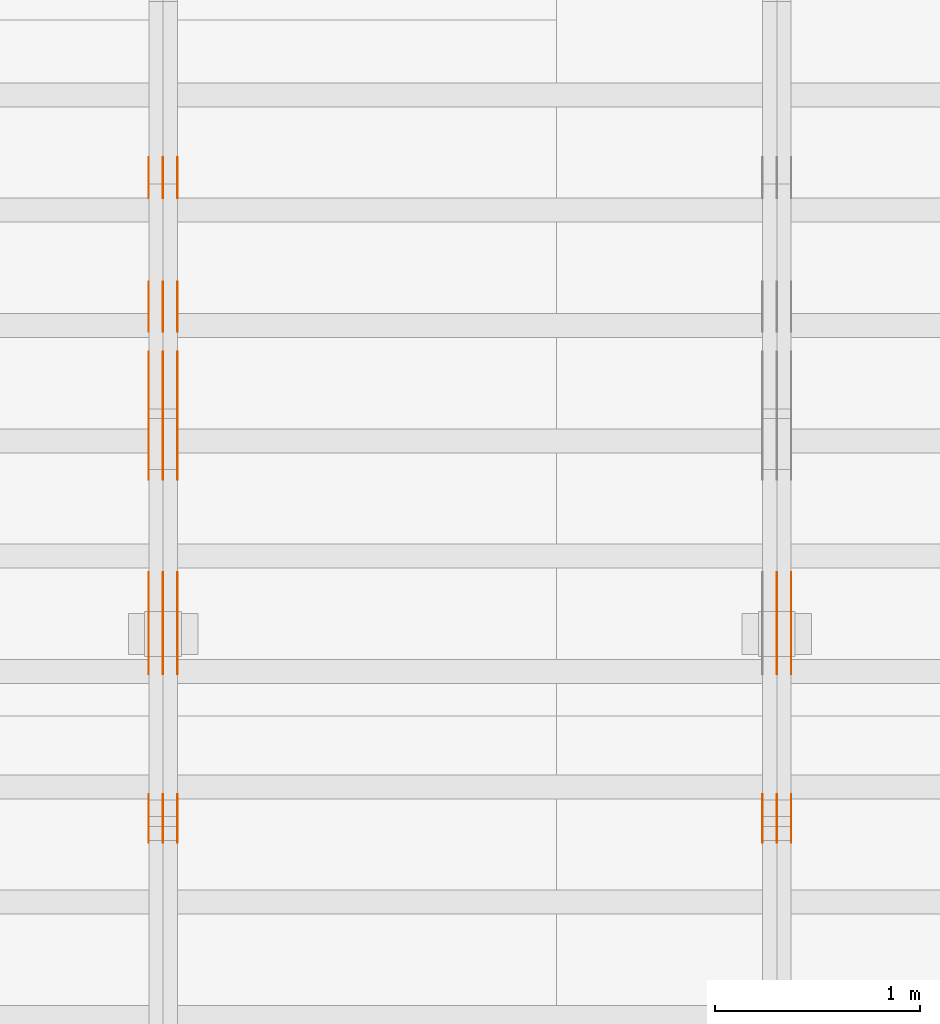
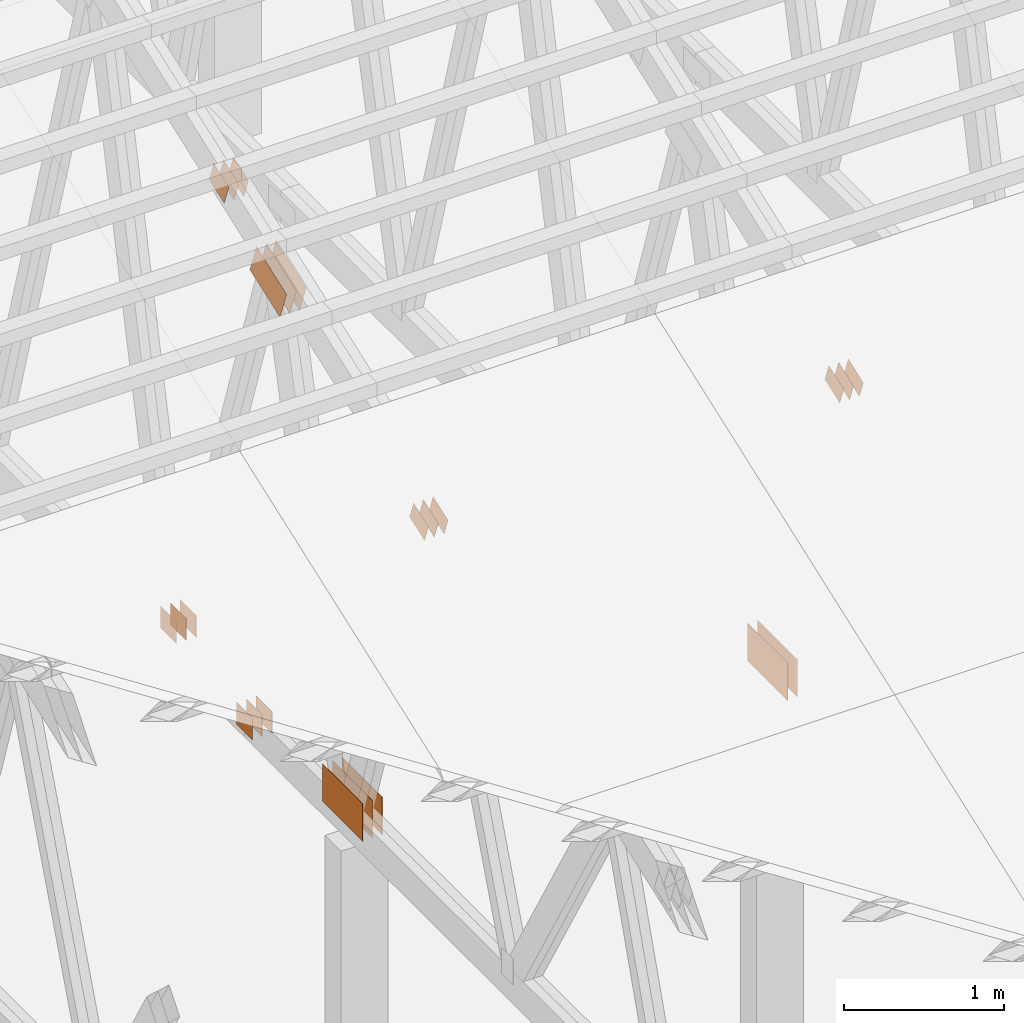
# One storey, part 145 of 189: 31 proxies.
"""IFC2X3 building model written with IfcOpenShell, lengths in millimetres."""

from ifc_helpers import new_model, entity, si_unit, converted_unit, derived_unit, direction, frame, frame_2d, origin, origin_2d_with_axis, place, context, subcontext, project, spatial, polyline, rectangle, outline, extrude, source, transform, mapped, material, type_object, type_shapes, element, save


model = new_model("IFC2X3")

# Units and contexts
model_context = context("Model", 3, precision=0.01, world=origin(), true_north=direction((6.12303176911189e-17, 1.0)))
body_context = subcontext(model_context, "Body", "Model", "MODEL_VIEW")
ifc_project = project(units=[si_unit("LENGTHUNIT", "METRE", prefix="MILLI"), si_unit("AREAUNIT", "SQUARE_METRE"), si_unit("VOLUMEUNIT", "CUBIC_METRE"), converted_unit("PLANEANGLEUNIT", "DEGREE", entity("IfcRatioMeasure", 0.0174532925199433), si_unit("PLANEANGLEUNIT", "RADIAN"), dimensions=[0, 0, 0, 0, 0, 0, 0]), si_unit("MASSUNIT", "GRAM", prefix="KILO"), derived_unit("MASSDENSITYUNIT", [(si_unit("MASSUNIT", "GRAM", prefix="KILO"), 1), (si_unit("LENGTHUNIT", "METRE"), -3)]), si_unit("TIMEUNIT", "SECOND"), si_unit("FREQUENCYUNIT", "HERTZ"), si_unit("THERMODYNAMICTEMPERATUREUNIT", "DEGREE_CELSIUS"), derived_unit("THERMALTRANSMITTANCEUNIT", [(si_unit("MASSUNIT", "GRAM", prefix="KILO"), 1), (si_unit("THERMODYNAMICTEMPERATUREUNIT", "KELVIN"), -1), (si_unit("TIMEUNIT", "SECOND"), -3)]), derived_unit("VOLUMETRICFLOWRATEUNIT", [(si_unit("LENGTHUNIT", "METRE"), 3), (si_unit("TIMEUNIT", "SECOND"), -1)]), si_unit("ELECTRICCURRENTUNIT", "AMPERE"), si_unit("ELECTRICVOLTAGEUNIT", "VOLT"), si_unit("POWERUNIT", "WATT"), si_unit("FORCEUNIT", "NEWTON"), si_unit("ILLUMINANCEUNIT", "LUX"), si_unit("LUMINOUSFLUXUNIT", "LUMEN"), si_unit("LUMINOUSINTENSITYUNIT", "CANDELA"), derived_unit("USERDEFINED", [(si_unit("MASSUNIT", "GRAM", prefix="KILO"), -1), (si_unit("LENGTHUNIT", "METRE"), -2), (si_unit("TIMEUNIT", "SECOND"), 3), (si_unit("LUMINOUSFLUXUNIT", "LUMEN"), 1)]), derived_unit("LINEARVELOCITYUNIT", [(si_unit("LENGTHUNIT", "METRE"), 1), (si_unit("TIMEUNIT", "SECOND"), -1)]), si_unit("PRESSUREUNIT", "PASCAL"), derived_unit("USERDEFINED", [(si_unit("LENGTHUNIT", "METRE"), -2), (si_unit("MASSUNIT", "GRAM", prefix="KILO"), 1), (si_unit("TIMEUNIT", "SECOND"), -2)])], contexts=[model_context])

# Site, building, storey
site_placement = place(None, origin())
site = spatial("IfcSite", under=ifc_project, at=site_placement, CompositionType="ELEMENT")
building_placement = place(site_placement, origin())
building = spatial("IfcBuilding", under=site, at=building_placement, CompositionType="ELEMENT")
storey_placement = place(building_placement, origin())
storey = spatial("IfcBuildingStorey", under=building, at=storey_placement, Name="Default", CompositionType="ELEMENT", Elevation=0.0)

# Proxies
ifc_material_1 = material(Name="IfcSurfaceStyle #202358")
building_element_proxy_type_1 = type_object("IfcBuildingElementProxyType", PredefinedType="NOTDEFINED", material=ifc_material_1)
shared_shape_1 = source(origin(), body_context, "Body", "SweptSolid", [
    extrude(rectangle(XDim=500.0, YDim=288.0, at=frame_2d((0.0, 1.4210854715202e-14), x_axis=(1.0, 0.0))), frame((250.000973740011, 144.0, 0.0), z_axis=(0.0, 0.0, 1.0), x_axis=(-1.0, 0.0, 0.0)), (0.0, 0.0, 1.0), 1.29999999999998),
])
type_shapes(building_element_proxy_type_1, [shared_shape_1])
proxy_1_placement = place(building_placement, frame((36301.3, 8551.90918250999, 389.0), z_axis=(-1.0, 0.0, 0.0), x_axis=(0.0, 1.0, 0.0)))
element("IfcBuildingElementProxy", 1, at=proxy_1_placement, inside=storey, type_object=building_element_proxy_type_1, material=ifc_material_1, context=body_context, shape_type="MappedRepresentation", body=[
    mapped(shared_shape_1, transform((0.0, 0.0, 0.0), scale=1.0)),
])
ifc_material_2 = material(Name="IfcSurfaceStyle #202301")
building_element_proxy_type_2 = type_object("IfcBuildingElementProxyType", PredefinedType="NOTDEFINED", material=ifc_material_2)
shared_shape_2 = source(origin(), body_context, "Body", "SweptSolid", [
    extrude(rectangle(XDim=500.0, YDim=288.0, at=frame_2d((0.0, 1.4210854715202e-14), x_axis=(1.0, 0.0))), frame((250.000973740011, 144.0, 0.0), z_axis=(0.0, 0.0, 1.0), x_axis=(-1.0, 0.0, 0.0)), (0.0, 0.0, 1.0), 1.29999999999997),
])
type_shapes(building_element_proxy_type_2, [shared_shape_2])
proxy_2_placement = place(building_placement, frame((36230.0, 8551.90918250999, 389.0), z_axis=(-1.0, 0.0, 0.0), x_axis=(0.0, 1.0, 0.0)))
element("IfcBuildingElementProxy", 2, at=proxy_2_placement, inside=storey, type_object=building_element_proxy_type_2, material=ifc_material_2, context=body_context, shape_type="MappedRepresentation", body=[
    mapped(shared_shape_2, transform((0.0, 0.0, 0.0), scale=1.0)),
])
ifc_material_3 = material(Name="IfcSurfaceStyle #202244")
building_element_proxy_type_3 = type_object("IfcBuildingElementProxyType", PredefinedType="NOTDEFINED", material=ifc_material_3)
shared_shape_3 = source(origin(), body_context, "Body", "SweptSolid", [
    extrude(rectangle(XDim=500.0, YDim=288.0, at=frame_2d((0.0, 1.4210854715202e-14), x_axis=(1.0, 0.0))), frame((250.000973740011, 144.0, 0.0), z_axis=(0.0, 0.0, 1.0), x_axis=(-1.0, 0.0, 0.0)), (0.0, 0.0, 1.0), 1.29999999999997),
])
type_shapes(building_element_proxy_type_3, [shared_shape_3])
proxy_3_placement = place(building_placement, frame((36231.3, 8551.90918250999, 389.0), z_axis=(-1.0, 0.0, 0.0), x_axis=(0.0, 1.0, 0.0)))
element("IfcBuildingElementProxy", 3, at=proxy_3_placement, inside=storey, type_object=building_element_proxy_type_3, material=ifc_material_3, context=body_context, shape_type="MappedRepresentation", body=[
    mapped(shared_shape_3, transform((0.0, 0.0, 0.0), scale=1.0)),
])
ifc_material_4 = material(Name="IfcSurfaceStyle #202130")
building_element_proxy_type_4 = type_object("IfcBuildingElementProxyType", PredefinedType="NOTDEFINED", material=ifc_material_4)
shared_shape_4 = source(origin(), body_context, "Body", "SweptSolid", [
    extrude(outline(polyline([(-100.00048713087, -72.0000025659129), (100.000394045495, -72.0000025659129), (99.9995694622958, 72.0000025659129), (-99.9994763769209, 72.0000025659128), (-100.00048713087, -72.0000025659129)])), frame((100.000394045495, 72.0000025659128, 0.0), z_axis=(0.0, 0.0, 1.0), x_axis=(-1.0, 0.0, 0.0)), (0.0, 0.0, 1.0), 1.3),
])
type_shapes(building_element_proxy_type_4, [shared_shape_4])
proxy_4_placement = place(building_placement, frame((36301.3, 7965.16887114408, 2936.19963864386), z_axis=(-1.0, 0.0, 0.0), x_axis=(0.0, -0.939692620785908, -0.342020143325669)))
element("IfcBuildingElementProxy", 4, at=proxy_4_placement, inside=storey, type_object=building_element_proxy_type_4, material=ifc_material_4, context=body_context, shape_type="MappedRepresentation", body=[
    mapped(shared_shape_4, transform((0.0, 0.0, 0.0), scale=1.0)),
])
ifc_material_5 = material(Name="IfcSurfaceStyle #202073")
building_element_proxy_type_5 = type_object("IfcBuildingElementProxyType", PredefinedType="NOTDEFINED", material=ifc_material_5)
shared_shape_5 = source(origin(), body_context, "Body", "SweptSolid", [
    extrude(outline(polyline([(-100.00048713087, -72.0000025659129), (100.000394045495, -72.0000025659129), (99.9995694622958, 72.0000025659129), (-99.9994763769209, 72.0000025659128), (-100.00048713087, -72.0000025659129)])), frame((100.000394045495, 72.0000025659128, 0.0), z_axis=(0.0, 0.0, 1.0), x_axis=(-1.0, 0.0, 0.0)), (0.0, 0.0, 1.0), 1.29999999999998),
])
type_shapes(building_element_proxy_type_5, [shared_shape_5])
proxy_5_placement = place(building_placement, frame((36230.0, 7965.16887114408, 2936.19963864386), z_axis=(-1.0, 0.0, 0.0), x_axis=(0.0, -0.939692620785908, -0.342020143325669)))
element("IfcBuildingElementProxy", 5, at=proxy_5_placement, inside=storey, type_object=building_element_proxy_type_5, material=ifc_material_5, context=body_context, shape_type="MappedRepresentation", body=[
    mapped(shared_shape_5, transform((0.0, 0.0, 0.0), scale=1.0)),
])
ifc_material_6 = material(Name="IfcSurfaceStyle #202016")
building_element_proxy_type_6 = type_object("IfcBuildingElementProxyType", PredefinedType="NOTDEFINED", material=ifc_material_6)
shared_shape_6 = source(origin(), body_context, "Body", "SweptSolid", [
    extrude(outline(polyline([(-100.00048713087, -72.0000025659129), (100.000394045495, -72.0000025659129), (99.9995694622958, 72.0000025659129), (-99.9994763769209, 72.0000025659128), (-100.00048713087, -72.0000025659129)])), frame((100.000394045495, 72.0000025659128, 0.0), z_axis=(0.0, 0.0, 1.0), x_axis=(-1.0, 0.0, 0.0)), (0.0, 0.0, 1.0), 1.29999999999998),
])
type_shapes(building_element_proxy_type_6, [shared_shape_6])
proxy_6_placement = place(building_placement, frame((36231.3, 7965.16887114408, 2936.19963864386), z_axis=(-1.0, 0.0, 0.0), x_axis=(0.0, -0.939692620785908, -0.342020143325669)))
element("IfcBuildingElementProxy", 6, at=proxy_6_placement, inside=storey, type_object=building_element_proxy_type_6, material=ifc_material_6, context=body_context, shape_type="MappedRepresentation", body=[
    mapped(shared_shape_6, transform((0.0, 0.0, 0.0), scale=1.0)),
])
ifc_material_7 = material(Name="IfcSurfaceStyle #201959")
building_element_proxy_type_7 = type_object("IfcBuildingElementProxyType", PredefinedType="NOTDEFINED", material=ifc_material_7)
shared_shape_7 = source(origin(), body_context, "Body", "SweptSolid", [
    extrude(outline(polyline([(-100.00048713087, -72.0000025659129), (100.000394045495, -72.0000025659129), (99.9995694622958, 72.0000025659129), (-99.9994763769209, 72.0000025659128), (-100.00048713087, -72.0000025659129)])), frame((100.000394045495, 72.0000025659128, 0.0), z_axis=(0.0, 0.0, 1.0), x_axis=(-1.0, 0.0, 0.0)), (0.0, 0.0, 1.0), 1.29999999999999),
])
type_shapes(building_element_proxy_type_7, [shared_shape_7])
proxy_7_placement = place(building_placement, frame((36160.0, 7965.16887114408, 2936.19963864386), z_axis=(-1.0, 0.0, 0.0), x_axis=(0.0, -0.939692620785908, -0.342020143325669)))
element("IfcBuildingElementProxy", 7, at=proxy_7_placement, inside=storey, type_object=building_element_proxy_type_7, material=ifc_material_7, context=body_context, shape_type="MappedRepresentation", body=[
    mapped(shared_shape_7, transform((0.0, 0.0, 0.0), scale=1.0)),
])
ifc_material_8 = material(Name="IfcSurfaceStyle #187480")
building_element_proxy_type_8 = type_object("IfcBuildingElementProxyType", PredefinedType="NOTDEFINED", material=ifc_material_8)
shared_shape_8 = source(origin(), body_context, "Body", "SweptSolid", [
    extrude(rectangle(XDim=200.0, YDim=168.0, at=origin_2d_with_axis()), frame((100.000765376775, 84.0, 0.0), z_axis=(0.0, 0.0, 1.0), x_axis=(-1.0, 0.0, 0.0)), (0.0, 0.0, 1.0), 1.3),
])
type_shapes(building_element_proxy_type_8, [shared_shape_8])
proxy_8_placement = place(building_placement, frame((33301.3, 10880.1574377482, 365.0), z_axis=(-1.0, 0.0, 0.0), x_axis=(0.0, 1.0, 0.0)))
element("IfcBuildingElementProxy", 8, at=proxy_8_placement, inside=storey, type_object=building_element_proxy_type_8, material=ifc_material_8, context=body_context, shape_type="MappedRepresentation", body=[
    mapped(shared_shape_8, transform((0.0, 0.0, 0.0), scale=1.0)),
])
ifc_material_9 = material(Name="IfcSurfaceStyle #187423")
building_element_proxy_type_9 = type_object("IfcBuildingElementProxyType", PredefinedType="NOTDEFINED", material=ifc_material_9)
shared_shape_9 = source(origin(), body_context, "Body", "SweptSolid", [
    extrude(rectangle(XDim=200.0, YDim=168.0, at=origin_2d_with_axis()), frame((100.000765376775, 84.0, 0.0), z_axis=(0.0, 0.0, 1.0), x_axis=(-1.0, 0.0, 0.0)), (0.0, 0.0, 1.0), 1.29999999999998),
])
type_shapes(building_element_proxy_type_9, [shared_shape_9])
proxy_9_placement = place(building_placement, frame((33230.0, 10880.1574377482, 365.0), z_axis=(-1.0, 0.0, 0.0), x_axis=(0.0, 1.0, 0.0)))
element("IfcBuildingElementProxy", 9, at=proxy_9_placement, inside=storey, type_object=building_element_proxy_type_9, material=ifc_material_9, context=body_context, shape_type="MappedRepresentation", body=[
    mapped(shared_shape_9, transform((0.0, 0.0, 0.0), scale=1.0)),
])
ifc_material_10 = material(Name="IfcSurfaceStyle #187366")
building_element_proxy_type_10 = type_object("IfcBuildingElementProxyType", PredefinedType="NOTDEFINED", material=ifc_material_10)
shared_shape_10 = source(origin(), body_context, "Body", "SweptSolid", [
    extrude(rectangle(XDim=200.0, YDim=168.0, at=origin_2d_with_axis()), frame((100.000765376775, 84.0, 0.0), z_axis=(0.0, 0.0, 1.0), x_axis=(-1.0, 0.0, 0.0)), (0.0, 0.0, 1.0), 1.29999999999998),
])
type_shapes(building_element_proxy_type_10, [shared_shape_10])
proxy_10_placement = place(building_placement, frame((33231.3, 10880.1574377482, 365.0), z_axis=(-1.0, 0.0, 0.0), x_axis=(0.0, 1.0, 0.0)))
element("IfcBuildingElementProxy", 10, at=proxy_10_placement, inside=storey, type_object=building_element_proxy_type_10, material=ifc_material_10, context=body_context, shape_type="MappedRepresentation", body=[
    mapped(shared_shape_10, transform((0.0, 0.0, 0.0), scale=1.0)),
])
ifc_material_11 = material(Name="IfcSurfaceStyle #187309")
building_element_proxy_type_11 = type_object("IfcBuildingElementProxyType", PredefinedType="NOTDEFINED", material=ifc_material_11)
shared_shape_11 = source(origin(), body_context, "Body", "SweptSolid", [
    extrude(rectangle(XDim=200.0, YDim=168.0, at=origin_2d_with_axis()), frame((100.000765376775, 84.0, 0.0), z_axis=(0.0, 0.0, 1.0), x_axis=(-1.0, 0.0, 0.0)), (0.0, 0.0, 1.0), 1.29999999999999),
])
type_shapes(building_element_proxy_type_11, [shared_shape_11])
proxy_11_placement = place(building_placement, frame((33160.0, 10880.1574377482, 365.0), z_axis=(-1.0, 0.0, 0.0), x_axis=(0.0, 1.0, 0.0)))
element("IfcBuildingElementProxy", 11, at=proxy_11_placement, inside=storey, type_object=building_element_proxy_type_11, material=ifc_material_11, context=body_context, shape_type="MappedRepresentation", body=[
    mapped(shared_shape_11, transform((0.0, 0.0, 0.0), scale=1.0)),
])
ifc_material_12 = material(Name="IfcSurfaceStyle #187252")
building_element_proxy_type_12 = type_object("IfcBuildingElementProxyType", PredefinedType="NOTDEFINED", material=ifc_material_12)
shared_shape_12 = source(origin(), body_context, "Body", "SweptSolid", [
    extrude(outline(polyline([(-199.999582244654, -119.99984375717), (200.000344770932, -119.99984375717), (199.999582244655, 119.99984375717), (-200.000344770934, 119.99984375717), (-199.999582244654, -119.99984375717)])), frame((200.000344770932, 120.0000091947, 0.0), z_axis=(0.0, 0.0, 1.0), x_axis=(-1.0, 0.0, 0.0)), (0.0, 0.0, 1.0), 1.29999999999999),
])
type_shapes(building_element_proxy_type_12, [shared_shape_12])
proxy_12_placement = place(building_placement, frame((33301.3, 9961.90704972973, 3612.2451494258), z_axis=(-1.0, 0.0, 0.0), x_axis=(0.0, -0.939692620785908, -0.342020143325669)))
element("IfcBuildingElementProxy", 12, at=proxy_12_placement, inside=storey, type_object=building_element_proxy_type_12, material=ifc_material_12, context=body_context, shape_type="MappedRepresentation", body=[
    mapped(shared_shape_12, transform((0.0, 0.0, 0.0), scale=1.0)),
])
ifc_material_13 = material(Name="IfcSurfaceStyle #187195")
building_element_proxy_type_13 = type_object("IfcBuildingElementProxyType", PredefinedType="NOTDEFINED", material=ifc_material_13)
shared_shape_13 = source(origin(), body_context, "Body", "SweptSolid", [
    extrude(outline(polyline([(-199.999582244654, -119.99984375717), (200.000344770932, -119.99984375717), (199.999582244655, 119.99984375717), (-200.000344770934, 119.99984375717), (-199.999582244654, -119.99984375717)])), frame((200.000344770932, 120.0000091947, 0.0), z_axis=(0.0, 0.0, 1.0), x_axis=(-1.0, 0.0, 0.0)), (0.0, 0.0, 1.0), 1.29999999999997),
])
type_shapes(building_element_proxy_type_13, [shared_shape_13])
proxy_13_placement = place(building_placement, frame((33230.0, 9961.90704972973, 3612.2451494258), z_axis=(-1.0, 0.0, 0.0), x_axis=(0.0, -0.939692620785908, -0.342020143325669)))
element("IfcBuildingElementProxy", 13, at=proxy_13_placement, inside=storey, type_object=building_element_proxy_type_13, material=ifc_material_13, context=body_context, shape_type="MappedRepresentation", body=[
    mapped(shared_shape_13, transform((0.0, 0.0, 0.0), scale=1.0)),
])
ifc_material_14 = material(Name="IfcSurfaceStyle #187138")
building_element_proxy_type_14 = type_object("IfcBuildingElementProxyType", PredefinedType="NOTDEFINED", material=ifc_material_14)
shared_shape_14 = source(origin(), body_context, "Body", "SweptSolid", [
    extrude(outline(polyline([(-199.999582244654, -119.99984375717), (200.000344770932, -119.99984375717), (199.999582244655, 119.99984375717), (-200.000344770934, 119.99984375717), (-199.999582244654, -119.99984375717)])), frame((200.000344770932, 120.0000091947, 0.0), z_axis=(0.0, 0.0, 1.0), x_axis=(-1.0, 0.0, 0.0)), (0.0, 0.0, 1.0), 1.29999999999997),
])
type_shapes(building_element_proxy_type_14, [shared_shape_14])
proxy_14_placement = place(building_placement, frame((33231.3, 9961.90704972973, 3612.2451494258), z_axis=(-1.0, 0.0, 0.0), x_axis=(0.0, -0.939692620785908, -0.342020143325669)))
element("IfcBuildingElementProxy", 14, at=proxy_14_placement, inside=storey, type_object=building_element_proxy_type_14, material=ifc_material_14, context=body_context, shape_type="MappedRepresentation", body=[
    mapped(shared_shape_14, transform((0.0, 0.0, 0.0), scale=1.0)),
])
ifc_material_15 = material(Name="IfcSurfaceStyle #187081")
building_element_proxy_type_15 = type_object("IfcBuildingElementProxyType", PredefinedType="NOTDEFINED", material=ifc_material_15)
shared_shape_15 = source(origin(), body_context, "Body", "SweptSolid", [
    extrude(outline(polyline([(-199.999582244654, -119.99984375717), (200.000344770932, -119.99984375717), (199.999582244655, 119.99984375717), (-200.000344770934, 119.99984375717), (-199.999582244654, -119.99984375717)])), frame((200.000344770932, 120.0000091947, 0.0), z_axis=(0.0, 0.0, 1.0), x_axis=(-1.0, 0.0, 0.0)), (0.0, 0.0, 1.0), 1.29999999999998),
])
type_shapes(building_element_proxy_type_15, [shared_shape_15])
proxy_15_placement = place(building_placement, frame((33160.0, 9961.90704972973, 3612.2451494258), z_axis=(-1.0, 0.0, 0.0), x_axis=(0.0, -0.939692620785908, -0.342020143325669)))
element("IfcBuildingElementProxy", 15, at=proxy_15_placement, inside=storey, type_object=building_element_proxy_type_15, material=ifc_material_15, context=body_context, shape_type="MappedRepresentation", body=[
    mapped(shared_shape_15, transform((0.0, 0.0, 0.0), scale=1.0)),
])
ifc_material_16 = material(Name="IfcSurfaceStyle #186568")
building_element_proxy_type_16 = type_object("IfcBuildingElementProxyType", PredefinedType="NOTDEFINED", material=ifc_material_16)
shared_shape_16 = source(origin(), body_context, "Body", "SweptSolid", [
    extrude(rectangle(XDim=500.0, YDim=288.0, at=frame_2d((0.0, 1.4210854715202e-14), x_axis=(1.0, 0.0))), frame((250.000973740011, 144.0, 0.0), z_axis=(0.0, 0.0, 1.0), x_axis=(-1.0, 0.0, 0.0)), (0.0, 0.0, 1.0), 1.29999999999998),
])
type_shapes(building_element_proxy_type_16, [shared_shape_16])
proxy_16_placement = place(building_placement, frame((33301.3, 8551.90918250999, 389.0), z_axis=(-1.0, 0.0, 0.0), x_axis=(0.0, 1.0, 0.0)))
element("IfcBuildingElementProxy", 16, at=proxy_16_placement, inside=storey, type_object=building_element_proxy_type_16, material=ifc_material_16, context=body_context, shape_type="MappedRepresentation", body=[
    mapped(shared_shape_16, transform((0.0, 0.0, 0.0), scale=1.0)),
])
ifc_material_17 = material(Name="IfcSurfaceStyle #186511")
building_element_proxy_type_17 = type_object("IfcBuildingElementProxyType", PredefinedType="NOTDEFINED", material=ifc_material_17)
shared_shape_17 = source(origin(), body_context, "Body", "SweptSolid", [
    extrude(rectangle(XDim=500.0, YDim=288.0, at=frame_2d((0.0, 1.4210854715202e-14), x_axis=(1.0, 0.0))), frame((250.000973740011, 144.0, 0.0), z_axis=(0.0, 0.0, 1.0), x_axis=(-1.0, 0.0, 0.0)), (0.0, 0.0, 1.0), 1.29999999999997),
])
type_shapes(building_element_proxy_type_17, [shared_shape_17])
proxy_17_placement = place(building_placement, frame((33230.0, 8551.90918250999, 389.0), z_axis=(-1.0, 0.0, 0.0), x_axis=(0.0, 1.0, 0.0)))
element("IfcBuildingElementProxy", 17, at=proxy_17_placement, inside=storey, type_object=building_element_proxy_type_17, material=ifc_material_17, context=body_context, shape_type="MappedRepresentation", body=[
    mapped(shared_shape_17, transform((0.0, 0.0, 0.0), scale=1.0)),
])
ifc_material_18 = material(Name="IfcSurfaceStyle #186454")
building_element_proxy_type_18 = type_object("IfcBuildingElementProxyType", PredefinedType="NOTDEFINED", material=ifc_material_18)
shared_shape_18 = source(origin(), body_context, "Body", "SweptSolid", [
    extrude(rectangle(XDim=500.0, YDim=288.0, at=frame_2d((0.0, 1.4210854715202e-14), x_axis=(1.0, 0.0))), frame((250.000973740011, 144.0, 0.0), z_axis=(0.0, 0.0, 1.0), x_axis=(-1.0, 0.0, 0.0)), (0.0, 0.0, 1.0), 1.29999999999997),
])
type_shapes(building_element_proxy_type_18, [shared_shape_18])
proxy_18_placement = place(building_placement, frame((33231.3, 8551.90918250999, 389.0), z_axis=(-1.0, 0.0, 0.0), x_axis=(0.0, 1.0, 0.0)))
element("IfcBuildingElementProxy", 18, at=proxy_18_placement, inside=storey, type_object=building_element_proxy_type_18, material=ifc_material_18, context=body_context, shape_type="MappedRepresentation", body=[
    mapped(shared_shape_18, transform((0.0, 0.0, 0.0), scale=1.0)),
])
ifc_material_19 = material(Name="IfcSurfaceStyle #186397")
building_element_proxy_type_19 = type_object("IfcBuildingElementProxyType", PredefinedType="NOTDEFINED", material=ifc_material_19)
shared_shape_19 = source(origin(), body_context, "Body", "SweptSolid", [
    extrude(rectangle(XDim=500.0, YDim=288.0, at=frame_2d((0.0, 1.4210854715202e-14), x_axis=(1.0, 0.0))), frame((250.000973740011, 144.0, 0.0), z_axis=(0.0, 0.0, 1.0), x_axis=(-1.0, 0.0, 0.0)), (0.0, 0.0, 1.0), 1.29999999999997),
])
type_shapes(building_element_proxy_type_19, [shared_shape_19])
proxy_19_placement = place(building_placement, frame((33160.0, 8551.90918250999, 389.0), z_axis=(-1.0, 0.0, 0.0), x_axis=(0.0, 1.0, 0.0)))
element("IfcBuildingElementProxy", 19, at=proxy_19_placement, inside=storey, type_object=building_element_proxy_type_19, material=ifc_material_19, context=body_context, shape_type="MappedRepresentation", body=[
    mapped(shared_shape_19, transform((0.0, 0.0, 0.0), scale=1.0)),
])
ifc_material_20 = material(Name="IfcSurfaceStyle #186340")
building_element_proxy_type_20 = type_object("IfcBuildingElementProxyType", PredefinedType="NOTDEFINED", material=ifc_material_20)
shared_shape_20 = source(origin(), body_context, "Body", "SweptSolid", [
    extrude(outline(polyline([(-100.00048713087, -72.0000025659129), (100.000394045495, -72.0000025659129), (99.9995694622958, 72.0000025659129), (-99.9994763769209, 72.0000025659128), (-100.00048713087, -72.0000025659129)])), frame((100.000394045495, 72.0000025659128, 0.0), z_axis=(0.0, 0.0, 1.0), x_axis=(-1.0, 0.0, 0.0)), (0.0, 0.0, 1.0), 1.3),
])
type_shapes(building_element_proxy_type_20, [shared_shape_20])
proxy_20_placement = place(building_placement, frame((33301.3, 7965.16887114408, 2936.19963864386), z_axis=(-1.0, 0.0, 0.0), x_axis=(0.0, -0.939692620785908, -0.342020143325669)))
element("IfcBuildingElementProxy", 20, at=proxy_20_placement, inside=storey, type_object=building_element_proxy_type_20, material=ifc_material_20, context=body_context, shape_type="MappedRepresentation", body=[
    mapped(shared_shape_20, transform((0.0, 0.0, 0.0), scale=1.0)),
])
ifc_material_21 = material(Name="IfcSurfaceStyle #186283")
building_element_proxy_type_21 = type_object("IfcBuildingElementProxyType", PredefinedType="NOTDEFINED", material=ifc_material_21)
shared_shape_21 = source(origin(), body_context, "Body", "SweptSolid", [
    extrude(outline(polyline([(-100.00048713087, -72.0000025659129), (100.000394045495, -72.0000025659129), (99.9995694622958, 72.0000025659129), (-99.9994763769209, 72.0000025659128), (-100.00048713087, -72.0000025659129)])), frame((100.000394045495, 72.0000025659128, 0.0), z_axis=(0.0, 0.0, 1.0), x_axis=(-1.0, 0.0, 0.0)), (0.0, 0.0, 1.0), 1.29999999999998),
])
type_shapes(building_element_proxy_type_21, [shared_shape_21])
proxy_21_placement = place(building_placement, frame((33230.0, 7965.16887114408, 2936.19963864386), z_axis=(-1.0, 0.0, 0.0), x_axis=(0.0, -0.939692620785908, -0.342020143325669)))
element("IfcBuildingElementProxy", 21, at=proxy_21_placement, inside=storey, type_object=building_element_proxy_type_21, material=ifc_material_21, context=body_context, shape_type="MappedRepresentation", body=[
    mapped(shared_shape_21, transform((0.0, 0.0, 0.0), scale=1.0)),
])
ifc_material_22 = material(Name="IfcSurfaceStyle #186226")
building_element_proxy_type_22 = type_object("IfcBuildingElementProxyType", PredefinedType="NOTDEFINED", material=ifc_material_22)
shared_shape_22 = source(origin(), body_context, "Body", "SweptSolid", [
    extrude(outline(polyline([(-100.00048713087, -72.0000025659129), (100.000394045495, -72.0000025659129), (99.9995694622958, 72.0000025659129), (-99.9994763769209, 72.0000025659128), (-100.00048713087, -72.0000025659129)])), frame((100.000394045495, 72.0000025659128, 0.0), z_axis=(0.0, 0.0, 1.0), x_axis=(-1.0, 0.0, 0.0)), (0.0, 0.0, 1.0), 1.29999999999998),
])
type_shapes(building_element_proxy_type_22, [shared_shape_22])
proxy_22_placement = place(building_placement, frame((33231.3, 7965.16887114408, 2936.19963864386), z_axis=(-1.0, 0.0, 0.0), x_axis=(0.0, -0.939692620785908, -0.342020143325669)))
element("IfcBuildingElementProxy", 22, at=proxy_22_placement, inside=storey, type_object=building_element_proxy_type_22, material=ifc_material_22, context=body_context, shape_type="MappedRepresentation", body=[
    mapped(shared_shape_22, transform((0.0, 0.0, 0.0), scale=1.0)),
])
ifc_material_23 = material(Name="IfcSurfaceStyle #186169")
building_element_proxy_type_23 = type_object("IfcBuildingElementProxyType", PredefinedType="NOTDEFINED", material=ifc_material_23)
shared_shape_23 = source(origin(), body_context, "Body", "SweptSolid", [
    extrude(outline(polyline([(-100.00048713087, -72.0000025659129), (100.000394045495, -72.0000025659129), (99.9995694622958, 72.0000025659129), (-99.9994763769209, 72.0000025659128), (-100.00048713087, -72.0000025659129)])), frame((100.000394045495, 72.0000025659128, 0.0), z_axis=(0.0, 0.0, 1.0), x_axis=(-1.0, 0.0, 0.0)), (0.0, 0.0, 1.0), 1.29999999999999),
])
type_shapes(building_element_proxy_type_23, [shared_shape_23])
proxy_23_placement = place(building_placement, frame((33160.0, 7965.16887114408, 2936.19963864386), z_axis=(-1.0, 0.0, 0.0), x_axis=(0.0, -0.939692620785908, -0.342020143325669)))
element("IfcBuildingElementProxy", 23, at=proxy_23_placement, inside=storey, type_object=building_element_proxy_type_23, material=ifc_material_23, context=body_context, shape_type="MappedRepresentation", body=[
    mapped(shared_shape_23, transform((0.0, 0.0, 0.0), scale=1.0)),
])
ifc_material_24 = material(Name="IfcSurfaceStyle #180928")
building_element_proxy_type_24 = type_object("IfcBuildingElementProxyType", PredefinedType="NOTDEFINED", material=ifc_material_24)
shared_shape_24 = source(origin(), body_context, "Body", "SweptSolid", [
    extrude(rectangle(XDim=200.0, YDim=168.0, at=origin_2d_with_axis()), frame((100.0, 84.0, 0.0), z_axis=(0.0, 0.0, 1.0), x_axis=(-1.0, 0.0, 0.0)), (0.0, 0.0, 1.0), 1.3),
])
type_shapes(building_element_proxy_type_24, [shared_shape_24])
proxy_24_placement = place(building_placement, frame((33301.3, 9929.23046875, 206.5), z_axis=(-1.0, 0.0, 0.0), x_axis=(0.0, 1.0, 0.0)))
element("IfcBuildingElementProxy", 24, at=proxy_24_placement, inside=storey, type_object=building_element_proxy_type_24, material=ifc_material_24, context=body_context, shape_type="MappedRepresentation", body=[
    mapped(shared_shape_24, transform((0.0, 0.0, 0.0), scale=1.0)),
])
ifc_material_25 = material(Name="IfcSurfaceStyle #180871")
building_element_proxy_type_25 = type_object("IfcBuildingElementProxyType", PredefinedType="NOTDEFINED", material=ifc_material_25)
shared_shape_25 = source(origin(), body_context, "Body", "SweptSolid", [
    extrude(rectangle(XDim=200.0, YDim=168.0, at=origin_2d_with_axis()), frame((100.0, 84.0, 0.0), z_axis=(0.0, 0.0, 1.0), x_axis=(-1.0, 0.0, 0.0)), (0.0, 0.0, 1.0), 1.29999999999998),
])
type_shapes(building_element_proxy_type_25, [shared_shape_25])
proxy_25_placement = place(building_placement, frame((33230.0, 9929.23046875, 206.5), z_axis=(-1.0, 0.0, 0.0), x_axis=(0.0, 1.0, 0.0)))
element("IfcBuildingElementProxy", 25, at=proxy_25_placement, inside=storey, type_object=building_element_proxy_type_25, material=ifc_material_25, context=body_context, shape_type="MappedRepresentation", body=[
    mapped(shared_shape_25, transform((0.0, 0.0, 0.0), scale=1.0)),
])
ifc_material_26 = material(Name="IfcSurfaceStyle #180814")
building_element_proxy_type_26 = type_object("IfcBuildingElementProxyType", PredefinedType="NOTDEFINED", material=ifc_material_26)
shared_shape_26 = source(origin(), body_context, "Body", "SweptSolid", [
    extrude(rectangle(XDim=200.0, YDim=168.0, at=origin_2d_with_axis()), frame((100.0, 84.0, 0.0), z_axis=(0.0, 0.0, 1.0), x_axis=(-1.0, 0.0, 0.0)), (0.0, 0.0, 1.0), 1.29999999999998),
])
type_shapes(building_element_proxy_type_26, [shared_shape_26])
proxy_26_placement = place(building_placement, frame((33231.3, 9929.23046875, 206.5), z_axis=(-1.0, 0.0, 0.0), x_axis=(0.0, 1.0, 0.0)))
element("IfcBuildingElementProxy", 26, at=proxy_26_placement, inside=storey, type_object=building_element_proxy_type_26, material=ifc_material_26, context=body_context, shape_type="MappedRepresentation", body=[
    mapped(shared_shape_26, transform((0.0, 0.0, 0.0), scale=1.0)),
])
ifc_material_27 = material(Name="IfcSurfaceStyle #180757")
building_element_proxy_type_27 = type_object("IfcBuildingElementProxyType", PredefinedType="NOTDEFINED", material=ifc_material_27)
shared_shape_27 = source(origin(), body_context, "Body", "SweptSolid", [
    extrude(rectangle(XDim=200.0, YDim=168.0, at=origin_2d_with_axis()), frame((100.0, 84.0, 0.0), z_axis=(0.0, 0.0, 1.0), x_axis=(-1.0, 0.0, 0.0)), (0.0, 0.0, 1.0), 1.29999999999999),
])
type_shapes(building_element_proxy_type_27, [shared_shape_27])
proxy_27_placement = place(building_placement, frame((33160.0, 9929.23046875, 206.5), z_axis=(-1.0, 0.0, 0.0), x_axis=(0.0, 1.0, 0.0)))
element("IfcBuildingElementProxy", 27, at=proxy_27_placement, inside=storey, type_object=building_element_proxy_type_27, material=ifc_material_27, context=body_context, shape_type="MappedRepresentation", body=[
    mapped(shared_shape_27, transform((0.0, 0.0, 0.0), scale=1.0)),
])
ifc_material_28 = material(Name="IfcSurfaceStyle #179848")
building_element_proxy_type_28 = type_object("IfcBuildingElementProxyType", PredefinedType="NOTDEFINED", material=ifc_material_28)
shared_shape_28 = source(origin(), body_context, "Body", "SweptSolid", [
    extrude(outline(polyline([(-100.00072430513, -84.0000258989549), (100.000156871239, -84.0000258989549), (99.9997648860508, 84.0000258989549), (-99.9991974521591, 84.0000258989548), (-100.00072430513, -84.0000258989549)])), frame((100.000156871239, 84.0000258989548, 0.0), z_axis=(0.0, 0.0, 1.0), x_axis=(-1.0, 0.0, 0.0)), (0.0, 0.0, 1.0), 1.3),
])
type_shapes(building_element_proxy_type_28, [shared_shape_28])
proxy_28_placement = place(building_placement, frame((33301.3, 10226.4409888304, 4081.14941482552), z_axis=(-1.0, 0.0, 0.0), x_axis=(0.0, 0.939692620785908, 0.342020143325669)))
element("IfcBuildingElementProxy", 28, at=proxy_28_placement, inside=storey, type_object=building_element_proxy_type_28, material=ifc_material_28, context=body_context, shape_type="MappedRepresentation", body=[
    mapped(shared_shape_28, transform((0.0, 0.0, 0.0), scale=1.0)),
])
ifc_material_29 = material(Name="IfcSurfaceStyle #179791")
building_element_proxy_type_29 = type_object("IfcBuildingElementProxyType", PredefinedType="NOTDEFINED", material=ifc_material_29)
shared_shape_29 = source(origin(), body_context, "Body", "SweptSolid", [
    extrude(outline(polyline([(-100.00072430513, -84.0000258989549), (100.000156871239, -84.0000258989549), (99.9997648860508, 84.0000258989549), (-99.9991974521591, 84.0000258989548), (-100.00072430513, -84.0000258989549)])), frame((100.000156871239, 84.0000258989548, 0.0), z_axis=(0.0, 0.0, 1.0), x_axis=(-1.0, 0.0, 0.0)), (0.0, 0.0, 1.0), 1.29999999999998),
])
type_shapes(building_element_proxy_type_29, [shared_shape_29])
proxy_29_placement = place(building_placement, frame((33230.0, 10226.4409888304, 4081.14941482552), z_axis=(-1.0, 0.0, 0.0), x_axis=(0.0, 0.939692620785908, 0.342020143325669)))
element("IfcBuildingElementProxy", 29, at=proxy_29_placement, inside=storey, type_object=building_element_proxy_type_29, material=ifc_material_29, context=body_context, shape_type="MappedRepresentation", body=[
    mapped(shared_shape_29, transform((0.0, 0.0, 0.0), scale=1.0)),
])
ifc_material_30 = material(Name="IfcSurfaceStyle #179734")
building_element_proxy_type_30 = type_object("IfcBuildingElementProxyType", PredefinedType="NOTDEFINED", material=ifc_material_30)
shared_shape_30 = source(origin(), body_context, "Body", "SweptSolid", [
    extrude(outline(polyline([(-100.00072430513, -84.0000258989549), (100.000156871239, -84.0000258989549), (99.9997648860508, 84.0000258989549), (-99.9991974521591, 84.0000258989548), (-100.00072430513, -84.0000258989549)])), frame((100.000156871239, 84.0000258989548, 0.0), z_axis=(0.0, 0.0, 1.0), x_axis=(-1.0, 0.0, 0.0)), (0.0, 0.0, 1.0), 1.29999999999998),
])
type_shapes(building_element_proxy_type_30, [shared_shape_30])
proxy_30_placement = place(building_placement, frame((33231.3, 10226.4409888304, 4081.14941482552), z_axis=(-1.0, 0.0, 0.0), x_axis=(0.0, 0.939692620785908, 0.342020143325669)))
element("IfcBuildingElementProxy", 30, at=proxy_30_placement, inside=storey, type_object=building_element_proxy_type_30, material=ifc_material_30, context=body_context, shape_type="MappedRepresentation", body=[
    mapped(shared_shape_30, transform((0.0, 0.0, 0.0), scale=1.0)),
])
ifc_material_31 = material(Name="IfcSurfaceStyle #179677")
building_element_proxy_type_31 = type_object("IfcBuildingElementProxyType", PredefinedType="NOTDEFINED", material=ifc_material_31)
shared_shape_31 = source(origin(), body_context, "Body", "SweptSolid", [
    extrude(outline(polyline([(-100.00072430513, -84.0000258989549), (100.000156871239, -84.0000258989549), (99.9997648860508, 84.0000258989549), (-99.9991974521591, 84.0000258989548), (-100.00072430513, -84.0000258989549)])), frame((100.000156871239, 84.0000258989548, 0.0), z_axis=(0.0, 0.0, 1.0), x_axis=(-1.0, 0.0, 0.0)), (0.0, 0.0, 1.0), 1.29999999999999),
])
type_shapes(building_element_proxy_type_31, [shared_shape_31])
proxy_31_placement = place(building_placement, frame((33160.0, 10226.4409888304, 4081.14941482552), z_axis=(-1.0, 0.0, 0.0), x_axis=(0.0, 0.939692620785908, 0.342020143325669)))
element("IfcBuildingElementProxy", 31, at=proxy_31_placement, inside=storey, type_object=building_element_proxy_type_31, material=ifc_material_31, context=body_context, shape_type="MappedRepresentation", body=[
    mapped(shared_shape_31, transform((0.0, 0.0, 0.0), scale=1.0)),
])

save(model, "model.ifc")
